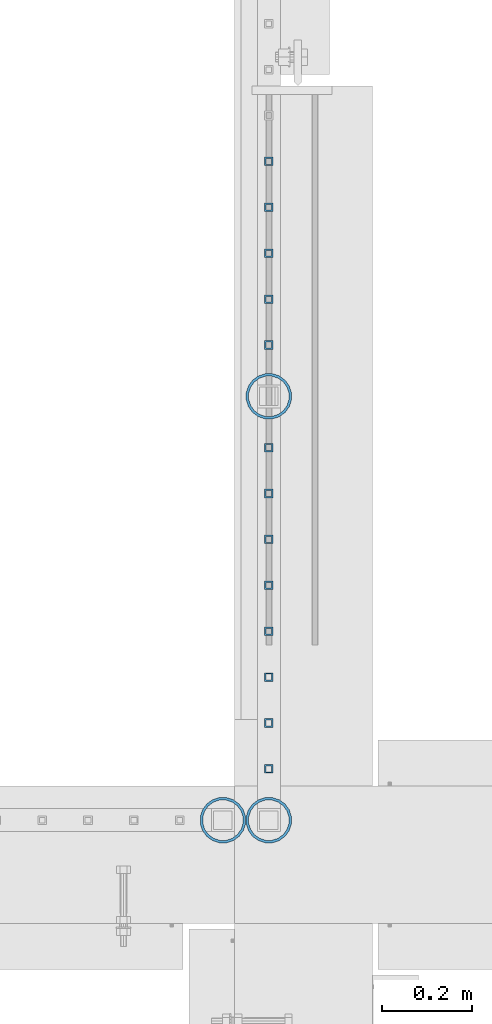
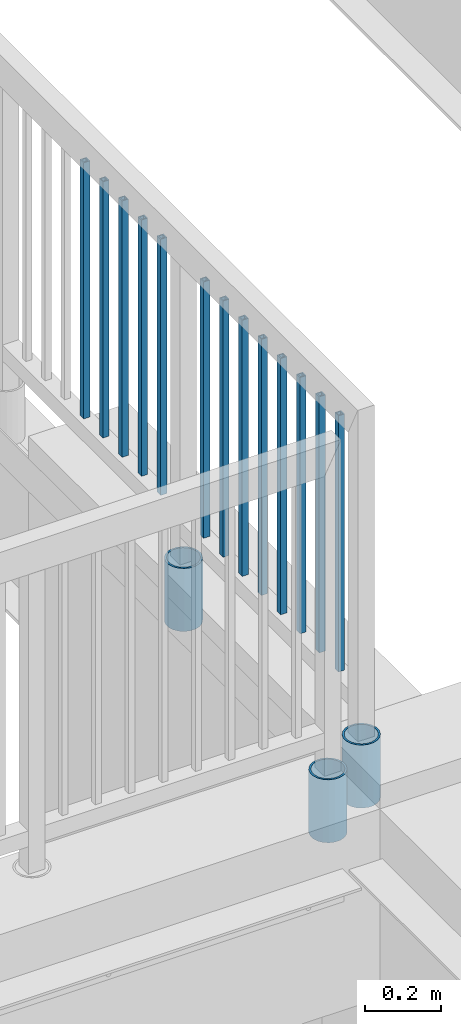
# One storey, part 212 of 975: 16 columns.
"""IFC2X3 building model written with IfcOpenShell, lengths in millimetres."""

from ifc_helpers import new_model, si_unit, frame, origin_with_axes, place, context, subcontext, project, spatial, faceted_brep, material, type_object, element, save


model = new_model("IFC2X3")

# Units and contexts
model_context = context("Model", 3, precision=1e-05, world=origin_with_axes())
body_context = subcontext(model_context, "Body", "Model", "MODEL_VIEW")
ifc_project = project(units=[si_unit("LENGTHUNIT", "METRE", prefix="MILLI"), si_unit("AREAUNIT", "SQUARE_METRE"), si_unit("VOLUMEUNIT", "CUBIC_METRE"), si_unit("MASSUNIT", "GRAM", prefix="KILO"), si_unit("TIMEUNIT", "SECOND"), si_unit("PLANEANGLEUNIT", "RADIAN"), si_unit("SOLIDANGLEUNIT", "STERADIAN"), si_unit("THERMODYNAMICTEMPERATUREUNIT", "DEGREE_CELSIUS"), si_unit("LUMINOUSINTENSITYUNIT", "LUMEN")], contexts=[model_context])

# Site, building, storey
site_placement = place(None, origin_with_axes())
site = spatial("IfcSite", under=ifc_project, at=site_placement, CompositionType="ELEMENT")
building_placement = place(site_placement, origin_with_axes())
building = spatial("IfcBuilding", under=site, at=building_placement, Name="Undefined", CompositionType="ELEMENT")
storey_placement = place(building_placement, origin_with_axes())
storey = spatial("IfcBuildingStorey", under=building, at=storey_placement, Name="Undefined", CompositionType="ELEMENT", Elevation=0.0)

# Columns
ifc_material_1 = material()
column_type_1 = type_object("IfcColumnType", Name="HSS3/4X3/4X.120_TUBES", PredefinedType="NOTDEFINED")
for number, where, z_axis, x_axis, name in (
    (1, (2091.7632059414, 22130.5416480171, 4254.50002056753), (0.0, 1.0, 0.0), (0.0, 0.0, 1.0), "PICKET"),
    (2, (2091.7632059414, 22028.9416480171, 4254.50002056753), (0.0, 1.0, 0.0), (0.0, 0.0, 1.0), "PICKET"),
    (3, (2091.7632059414, 21927.3416480171, 4254.50002056753), (0.0, 1.0, 0.0), (0.0, 0.0, 1.0), "PICKET"),
    (4, (2091.7632059414, 21825.7416480171, 4254.50002056753), (0.0, 1.0, 0.0), (0.0, 0.0, 1.0), "PICKET"),
    (5, (2091.7632059414, 21724.1416480171, 4254.50002056753), (0.0, 1.0, 0.0), (0.0, 0.0, 1.0), "PICKET"),
    (6, (2091.75174267054, 21497.1270920987, 4254.50352506861), (0.0, 1.0, 0.0), (0.0, 0.0, 1.0), "PICKET"),
    (7, (2091.75174267054, 21395.5270920987, 4254.50352506861), (0.0, 1.0, 0.0), (0.0, 0.0, 1.0), "PICKET"),
    (8, (2091.75174267054, 21293.9270920987, 4254.50352506861), (0.0, 1.0, 0.0), (0.0, 0.0, 1.0), "PICKET"),
    (9, (2091.75174267054, 21192.3270920987, 4254.50352506861), (0.0, 1.0, 0.0), (0.0, 0.0, 1.0), "PICKET"),
    (10, (2091.75174267054, 21090.7270920987, 4254.50352506861), (0.0, 1.0, 0.0), (0.0, 0.0, 1.0), "PICKET"),
    (11, (2091.75174267054, 20989.1270920987, 4254.50352506861), (0.0, 1.0, 0.0), (0.0, 0.0, 1.0), "PICKET"),
    (12, (2091.75174267054, 20887.5270920987, 4254.50352506861), (0.0, 1.0, 0.0), (0.0, 0.0, 1.0), "PICKET"),
    (13, (2091.75174267054, 20785.9270920987, 4254.50352506861), (0.0, 1.0, 0.0), (0.0, 0.0, 1.0), "PICKET"),
):
    element("IfcColumn", number, at=place(storey_placement, frame(where, z_axis=z_axis, x_axis=x_axis)), inside=storey, type_object=column_type_1, material=ifc_material_1, Name=name, ObjectType="HSS3/4X3/4X.120_TUBES", context=body_context, shape_type="Brep", body=[
        faceted_brep([(0.0, 6.34999999998763, -6.34999999998763), (0.0, -6.35000000000582, -6.34999999998763), (825.49997943247, -6.35000000000582, -6.34999999998763), (825.49997943247, 6.34999999998763, -6.34999999998763), (0.0, -6.34999999998763, 6.34999999998763), (825.49997943247, -6.34999999998763, 6.34999999998763), (0.0, 6.35000000000946, 6.34999999998763), (825.49997943247, 6.35000000000946, 6.34999999998763), (0.0, 9.52499999997963, -9.52499999997963), (0.0, 9.52500000000873, 9.5249999999869), (825.49997943247, 9.52500000000873, 9.5249999999869), (825.49997943247, 9.52499999997963, -9.52499999997963), (0.0, -9.52499999997963, 9.52499999998327), (825.49997943247, -9.52499999997963, 9.52499999998327), (0.0, -9.52500000000873, -9.5249999999869), (825.49997943247, -9.52500000000873, -9.5249999999869)], [[[0, 1, 2, 3]], [[1, 4, 5, 2]], [[4, 6, 7, 5]], [[6, 0, 3, 7]], [[8, 9, 10, 11]], [[9, 12, 13, 10]], [[12, 14, 15, 13]], [[14, 8, 11, 15]], [[13, 15, 11, 10], [5, 7, 3, 2]], [[14, 12, 9, 8], [6, 4, 1, 0]]]),
    ])
ifc_material_2 = material(Name="STEEL/A53")
column_type_2 = type_object("IfcColumnType", Name="PIPE3-1/2STD", PredefinedType="NOTDEFINED")
column_1_placement = place(storey_placement, frame((1990.12300113828, 20672.4250004, 3835.40001060704), z_axis=(-0.707106781186601, 0.707106781186494, 2.36468622460961e-14), x_axis=(0.0, 0.0, 1.0)))
element("IfcColumn", 14, at=column_1_placement, inside=storey, type_object=column_type_2, material=ifc_material_2, ObjectType="PIPE3-1/2STD", context=body_context, shape_type="Brep", body=[
    faceted_brep([(0.0, -45.0595999999932, 1.45519152283669e-11), (0.0, -42.8542262016344, 13.924182159768), (203.199999999991, -42.8542262017145, 13.9241821598171), (203.19999999999, -45.0596000000478, 5.82076609134674e-11), (0.0, -36.45398215971, 26.4853683542424), (203.199999999993, -36.45398215981, 26.4853683542988), (0.0, -26.4853683541623, 36.45398215979), (203.199999999995, -26.4853683542788, 36.4539821598537), (0.0, -13.9241821596988, 42.8542262017108), (203.199999999998, -13.9241821598262, 42.8542262017836), (0.0, 3.63797880709171e-11, 45.0596000000514), (203.2, -9.27684595808387e-11, 45.0596000001387), (0.0, 13.9241821597716, 42.8542262017036), (203.200000000003, 13.9241821596443, 42.8542262017927), (0.0, 26.4853683542242, 36.4539821597718), (203.200000000006, 26.4853683541096, 36.4539821598701), (0.0, 36.4539821597537, 26.4853683542206), (203.200000000008, 36.4539821596554, 26.4853683543224), (0.0, 42.8542262016563, 13.9241821597425), (203.200000000009, 42.8542262015817, 13.9241821598443), (0.0, 45.0595999999932, -1.09139364212751e-11), (203.200000000009, 45.0595999999423, 8.9130480773747e-11), (0.0, 42.8542262016344, -13.9241821597643), (203.200000000008, 42.854226201609, -13.9241821596697), (0.0, 36.45398215971, -26.4853683542387), (203.200000000007, 36.4539821597045, -26.4853683541514), (0.0, 26.4853683541623, -36.4539821597864), (203.200000000004, 26.4853683541733, -36.4539821597064), (0.0, 13.9241821596988, -42.8542262017072), (203.200000000002, 13.9241821597225, -42.8542262016381), (0.0, -3.63797880709171e-11, -45.0596000000478), (203.199999999999, -9.09494701772928e-12, -45.0595999999914), (0.0, -13.9241821597716, -42.8542262016963), (203.199999999996, -13.9241821597479, -42.8542262016472), (0.0, -26.4853683542242, -36.4539821597682), (203.199999999993, -26.4853683542133, -36.4539821597227), (0.0, -36.4539821597537, -26.4853683542169), (203.199999999992, -36.4539821597609, -26.4853683541751), (0.0, -42.8542262016563, -13.9241821597352), (203.199999999991, -42.8542262016872, -13.924182159697), (0.0, -50.799999999992, 1.81898940354586e-11), (0.0, -48.3136710278013, -15.6980633142484), (203.199999999989, -48.313671027825, -15.6980633142139), (203.199999999989, -50.8000000000466, 5.63886715099216e-11), (0.0, -41.0980633142644, -29.8594908164741), (203.19999999999, -41.0980633142663, -29.8594908164414), (0.0, -29.859490816485, -41.0980633142826), (203.199999999993, -29.8594908164687, -41.0980633142426), (0.0, -15.6980633142848, -48.313671027845), (203.199999999995, -15.6980633142539, -48.313671027794), (0.0, -4.36557456851006e-11, -50.8000000000575), (203.199999999998, -7.27595761418343e-12, -50.7999999999993), (0.0, 15.6980633142011, -48.3136710278523), (203.200000000002, 15.6980633142375, -48.3136710277831), (0.0, 29.8594908164159, -41.0980633143045), (203.200000000005, 29.8594908164378, -41.0980633142226), (0.0, 41.0980633142135, -29.8594908165032), (203.200000000008, 41.0980633142171, -29.8594908164141), (0.0, 48.3136710277722, -15.6980633142775), (203.200000000009, 48.3136710277504, -15.6980633141811), (0.0, 50.799999999992, -1.45519152283669e-11), (203.20000000001, 50.7999999999411, 9.09494701772928e-11), (0.0, 48.313671027794, 15.6980633142521), (203.20000000001, 48.3136710277213, 15.6980633143594), (0.0, 41.0980633142644, 29.8594908164814), (203.200000000008, 41.0980633141626, 29.8594908165887), (0.0, 29.859490816485, 41.0980633142863), (203.200000000007, 29.8594908163632, 41.0980633143899), (0.0, 15.6980633142848, 48.3136710278486), (203.200000000004, 15.6980633141484, 48.3136710279414), (0.0, 4.00177668780088e-11, 50.8000000000611), (203.200000000001, -9.82254277914762e-11, 50.8000000001466), (0.0, -15.6980633142011, 48.3136710278559), (203.199999999997, -15.698063314343, 48.3136710279305), (0.0, -29.8594908164159, 41.0980633143081), (203.199999999994, -29.8594908165433, 41.0980633143681), (0.0, -41.0980633142171, 29.8594908165069), (203.199999999992, -41.0980633143226, 29.8594908165596), (0.0, -48.3136710277722, 15.6980633142812), (203.19999999999, -48.3136710278559, 15.6980633143285)], [[[0, 1, 2, 3]], [[1, 4, 5, 2]], [[4, 6, 7, 5]], [[6, 8, 9, 7]], [[8, 10, 11, 9]], [[10, 12, 13, 11]], [[12, 14, 15, 13]], [[14, 16, 17, 15]], [[16, 18, 19, 17]], [[18, 20, 21, 19]], [[20, 22, 23, 21]], [[22, 24, 25, 23]], [[24, 26, 27, 25]], [[26, 28, 29, 27]], [[28, 30, 31, 29]], [[30, 32, 33, 31]], [[32, 34, 35, 33]], [[34, 36, 37, 35]], [[36, 38, 39, 37]], [[38, 0, 3, 39]], [[40, 41, 42, 43]], [[41, 44, 45, 42]], [[44, 46, 47, 45]], [[46, 48, 49, 47]], [[48, 50, 51, 49]], [[50, 52, 53, 51]], [[52, 54, 55, 53]], [[54, 56, 57, 55]], [[56, 58, 59, 57]], [[58, 60, 61, 59]], [[60, 62, 63, 61]], [[62, 64, 65, 63]], [[64, 66, 67, 65]], [[66, 68, 69, 67]], [[68, 70, 71, 69]], [[70, 72, 73, 71]], [[72, 74, 75, 73]], [[74, 76, 77, 75]], [[76, 78, 79, 77]], [[78, 40, 43, 79]], [[45, 47, 49, 51, 53, 55, 57, 59, 61, 63, 65, 67, 69, 71, 73, 75, 77, 79, 43, 42], [5, 7, 9, 11, 13, 15, 17, 19, 21, 23, 25, 27, 29, 31, 33, 35, 37, 39, 3, 2]], [[78, 76, 74, 72, 70, 68, 66, 64, 62, 60, 58, 56, 54, 52, 50, 48, 46, 44, 41, 40], [38, 36, 34, 32, 30, 28, 26, 24, 22, 20, 18, 16, 14, 12, 10, 8, 6, 4, 1, 0]]]),
])
column_2_placement = place(storey_placement, frame((2091.72299802514, 20672.4250004, 3911.6), z_axis=(-0.707106781186601, 0.707106781186494, 2.36468622460961e-14), x_axis=(0.0, 0.0, 1.0)))
element("IfcColumn", 15, at=column_2_placement, inside=storey, type_object=column_type_2, material=ifc_material_2, ObjectType="PIPE3-1/2STD", context=body_context, shape_type="Brep", body=[
    faceted_brep([(0.0, -45.0595999999932, 1.45519152283669e-11), (0.0, -42.8542262016344, 13.924182159768), (203.199999999991, -42.8542262017145, 13.9241821598171), (203.19999999999, -45.0596000000478, 5.82076609134674e-11), (0.0, -36.45398215971, 26.4853683542424), (203.199999999993, -36.45398215981, 26.4853683542988), (0.0, -26.4853683541623, 36.45398215979), (203.199999999995, -26.4853683542788, 36.4539821598537), (0.0, -13.9241821596988, 42.8542262017108), (203.199999999998, -13.9241821598262, 42.8542262017836), (0.0, 3.63797880709171e-11, 45.0596000000514), (203.2, -9.27684595808387e-11, 45.0596000001387), (0.0, 13.9241821597716, 42.8542262017036), (203.200000000003, 13.9241821596443, 42.8542262017927), (0.0, 26.4853683542242, 36.4539821597718), (203.200000000006, 26.4853683541096, 36.4539821598701), (0.0, 36.4539821597537, 26.4853683542206), (203.200000000008, 36.4539821596554, 26.4853683543224), (0.0, 42.8542262016563, 13.9241821597425), (203.200000000009, 42.8542262015817, 13.9241821598443), (0.0, 45.0595999999932, -1.09139364212751e-11), (203.200000000009, 45.0595999999423, 8.9130480773747e-11), (0.0, 42.8542262016344, -13.9241821597643), (203.200000000008, 42.854226201609, -13.9241821596697), (0.0, 36.45398215971, -26.4853683542387), (203.200000000007, 36.4539821597045, -26.4853683541514), (0.0, 26.4853683541623, -36.4539821597864), (203.200000000004, 26.4853683541733, -36.4539821597064), (0.0, 13.9241821596988, -42.8542262017072), (203.200000000002, 13.9241821597225, -42.8542262016381), (0.0, -3.63797880709171e-11, -45.0596000000478), (203.199999999999, -9.09494701772928e-12, -45.0595999999914), (0.0, -13.9241821597716, -42.8542262016963), (203.199999999996, -13.9241821597479, -42.8542262016472), (0.0, -26.4853683542242, -36.4539821597682), (203.199999999993, -26.4853683542133, -36.4539821597227), (0.0, -36.4539821597537, -26.4853683542169), (203.199999999992, -36.4539821597609, -26.4853683541751), (0.0, -42.8542262016563, -13.9241821597352), (203.199999999991, -42.8542262016872, -13.924182159697), (0.0, -50.799999999992, 1.81898940354586e-11), (0.0, -48.3136710278013, -15.6980633142484), (203.199999999989, -48.313671027825, -15.6980633142139), (203.199999999989, -50.8000000000466, 5.63886715099216e-11), (0.0, -41.0980633142644, -29.8594908164741), (203.19999999999, -41.0980633142663, -29.8594908164414), (0.0, -29.859490816485, -41.0980633142826), (203.199999999993, -29.8594908164687, -41.0980633142426), (0.0, -15.6980633142848, -48.313671027845), (203.199999999995, -15.6980633142539, -48.313671027794), (0.0, -4.36557456851006e-11, -50.8000000000575), (203.199999999998, -7.27595761418343e-12, -50.7999999999993), (0.0, 15.6980633142011, -48.3136710278523), (203.200000000002, 15.6980633142375, -48.3136710277831), (0.0, 29.8594908164159, -41.0980633143045), (203.200000000005, 29.8594908164378, -41.0980633142226), (0.0, 41.0980633142135, -29.8594908165032), (203.200000000008, 41.0980633142171, -29.8594908164141), (0.0, 48.3136710277722, -15.6980633142775), (203.200000000009, 48.3136710277504, -15.6980633141811), (0.0, 50.799999999992, -1.45519152283669e-11), (203.20000000001, 50.7999999999411, 9.09494701772928e-11), (0.0, 48.313671027794, 15.6980633142521), (203.20000000001, 48.3136710277213, 15.6980633143594), (0.0, 41.0980633142644, 29.8594908164814), (203.200000000008, 41.0980633141626, 29.8594908165887), (0.0, 29.859490816485, 41.0980633142863), (203.200000000007, 29.8594908163632, 41.0980633143899), (0.0, 15.6980633142848, 48.3136710278486), (203.200000000004, 15.6980633141484, 48.3136710279414), (0.0, 4.00177668780088e-11, 50.8000000000611), (203.200000000001, -9.82254277914762e-11, 50.8000000001466), (0.0, -15.6980633142011, 48.3136710278559), (203.199999999997, -15.698063314343, 48.3136710279305), (0.0, -29.8594908164159, 41.0980633143081), (203.199999999994, -29.8594908165433, 41.0980633143681), (0.0, -41.0980633142171, 29.8594908165069), (203.199999999992, -41.0980633143226, 29.8594908165596), (0.0, -48.3136710277722, 15.6980633142812), (203.19999999999, -48.3136710278559, 15.6980633143285)], [[[0, 1, 2, 3]], [[1, 4, 5, 2]], [[4, 6, 7, 5]], [[6, 8, 9, 7]], [[8, 10, 11, 9]], [[10, 12, 13, 11]], [[12, 14, 15, 13]], [[14, 16, 17, 15]], [[16, 18, 19, 17]], [[18, 20, 21, 19]], [[20, 22, 23, 21]], [[22, 24, 25, 23]], [[24, 26, 27, 25]], [[26, 28, 29, 27]], [[28, 30, 31, 29]], [[30, 32, 33, 31]], [[32, 34, 35, 33]], [[34, 36, 37, 35]], [[36, 38, 39, 37]], [[38, 0, 3, 39]], [[40, 41, 42, 43]], [[41, 44, 45, 42]], [[44, 46, 47, 45]], [[46, 48, 49, 47]], [[48, 50, 51, 49]], [[50, 52, 53, 51]], [[52, 54, 55, 53]], [[54, 56, 57, 55]], [[56, 58, 59, 57]], [[58, 60, 61, 59]], [[60, 62, 63, 61]], [[62, 64, 65, 63]], [[64, 66, 67, 65]], [[66, 68, 69, 67]], [[68, 70, 71, 69]], [[70, 72, 73, 71]], [[72, 74, 75, 73]], [[74, 76, 77, 75]], [[76, 78, 79, 77]], [[78, 40, 43, 79]], [[45, 47, 49, 51, 53, 55, 57, 59, 61, 63, 65, 67, 69, 71, 73, 75, 77, 79, 43, 42], [5, 7, 9, 11, 13, 15, 17, 19, 21, 23, 25, 27, 29, 31, 33, 35, 37, 39, 3, 2]], [[78, 76, 74, 72, 70, 68, 66, 64, 62, 60, 58, 56, 54, 52, 50, 48, 46, 44, 41, 40], [38, 36, 34, 32, 30, 28, 26, 24, 22, 20, 18, 16, 14, 12, 10, 8, 6, 4, 1, 0]]]),
])
column_3_placement = place(storey_placement, frame((2091.7784545645, 21610.6328162327, 3911.6), z_axis=(-0.707106781186601, 0.707106781186494, 2.36468622460961e-14), x_axis=(0.0, 0.0, 1.0)))
element("IfcColumn", 16, at=column_3_placement, inside=storey, type_object=column_type_2, material=ifc_material_2, ObjectType="PIPE3-1/2STD", context=body_context, shape_type="Brep", body=[
    faceted_brep([(0.0, -45.0595999999932, 1.45519152283669e-11), (0.0, -42.8542262016344, 13.924182159768), (203.199999999991, -42.8542262017145, 13.9241821598171), (203.19999999999, -45.0596000000478, 5.82076609134674e-11), (0.0, -36.45398215971, 26.4853683542424), (203.199999999993, -36.45398215981, 26.4853683542988), (0.0, -26.4853683541623, 36.45398215979), (203.199999999995, -26.4853683542788, 36.4539821598537), (0.0, -13.9241821596988, 42.8542262017108), (203.199999999998, -13.9241821598262, 42.8542262017836), (0.0, 3.63797880709171e-11, 45.0596000000514), (203.2, -9.27684595808387e-11, 45.0596000001387), (0.0, 13.9241821597716, 42.8542262017036), (203.200000000003, 13.9241821596443, 42.8542262017927), (0.0, 26.4853683542242, 36.4539821597718), (203.200000000006, 26.4853683541096, 36.4539821598701), (0.0, 36.4539821597537, 26.4853683542206), (203.200000000008, 36.4539821596554, 26.4853683543224), (0.0, 42.8542262016563, 13.9241821597425), (203.200000000009, 42.8542262015817, 13.9241821598443), (0.0, 45.0595999999932, -1.09139364212751e-11), (203.200000000009, 45.0595999999423, 8.9130480773747e-11), (0.0, 42.8542262016344, -13.9241821597643), (203.200000000008, 42.854226201609, -13.9241821596697), (0.0, 36.45398215971, -26.4853683542387), (203.200000000007, 36.4539821597045, -26.4853683541514), (0.0, 26.4853683541623, -36.4539821597864), (203.200000000004, 26.4853683541733, -36.4539821597064), (0.0, 13.9241821596988, -42.8542262017072), (203.200000000002, 13.9241821597225, -42.8542262016381), (0.0, -3.63797880709171e-11, -45.0596000000478), (203.199999999999, -9.09494701772928e-12, -45.0595999999914), (0.0, -13.9241821597716, -42.8542262016963), (203.199999999996, -13.9241821597479, -42.8542262016472), (0.0, -26.4853683542242, -36.4539821597682), (203.199999999993, -26.4853683542133, -36.4539821597227), (0.0, -36.4539821597537, -26.4853683542169), (203.199999999992, -36.4539821597609, -26.4853683541751), (0.0, -42.8542262016563, -13.9241821597352), (203.199999999991, -42.8542262016872, -13.924182159697), (0.0, -50.799999999992, 1.81898940354586e-11), (0.0, -48.3136710278013, -15.6980633142484), (203.199999999989, -48.313671027825, -15.6980633142139), (203.199999999989, -50.8000000000466, 5.63886715099216e-11), (0.0, -41.0980633142644, -29.8594908164741), (203.19999999999, -41.0980633142663, -29.8594908164414), (0.0, -29.859490816485, -41.0980633142826), (203.199999999993, -29.8594908164687, -41.0980633142426), (0.0, -15.6980633142848, -48.313671027845), (203.199999999995, -15.6980633142539, -48.313671027794), (0.0, -4.36557456851006e-11, -50.8000000000575), (203.199999999998, -7.27595761418343e-12, -50.7999999999993), (0.0, 15.6980633142011, -48.3136710278523), (203.200000000002, 15.6980633142375, -48.3136710277831), (0.0, 29.8594908164159, -41.0980633143045), (203.200000000005, 29.8594908164378, -41.0980633142226), (0.0, 41.0980633142135, -29.8594908165032), (203.200000000008, 41.0980633142171, -29.8594908164141), (0.0, 48.3136710277722, -15.6980633142775), (203.200000000009, 48.3136710277504, -15.6980633141811), (0.0, 50.799999999992, -1.45519152283669e-11), (203.20000000001, 50.7999999999411, 9.09494701772928e-11), (0.0, 48.313671027794, 15.6980633142521), (203.20000000001, 48.3136710277213, 15.6980633143594), (0.0, 41.0980633142644, 29.8594908164814), (203.200000000008, 41.0980633141626, 29.8594908165887), (0.0, 29.859490816485, 41.0980633142863), (203.200000000007, 29.8594908163632, 41.0980633143899), (0.0, 15.6980633142848, 48.3136710278486), (203.200000000004, 15.6980633141484, 48.3136710279414), (0.0, 4.00177668780088e-11, 50.8000000000611), (203.200000000001, -9.82254277914762e-11, 50.8000000001466), (0.0, -15.6980633142011, 48.3136710278559), (203.199999999997, -15.698063314343, 48.3136710279305), (0.0, -29.8594908164159, 41.0980633143081), (203.199999999994, -29.8594908165433, 41.0980633143681), (0.0, -41.0980633142171, 29.8594908165069), (203.199999999992, -41.0980633143226, 29.8594908165596), (0.0, -48.3136710277722, 15.6980633142812), (203.19999999999, -48.3136710278559, 15.6980633143285)], [[[0, 1, 2, 3]], [[1, 4, 5, 2]], [[4, 6, 7, 5]], [[6, 8, 9, 7]], [[8, 10, 11, 9]], [[10, 12, 13, 11]], [[12, 14, 15, 13]], [[14, 16, 17, 15]], [[16, 18, 19, 17]], [[18, 20, 21, 19]], [[20, 22, 23, 21]], [[22, 24, 25, 23]], [[24, 26, 27, 25]], [[26, 28, 29, 27]], [[28, 30, 31, 29]], [[30, 32, 33, 31]], [[32, 34, 35, 33]], [[34, 36, 37, 35]], [[36, 38, 39, 37]], [[38, 0, 3, 39]], [[40, 41, 42, 43]], [[41, 44, 45, 42]], [[44, 46, 47, 45]], [[46, 48, 49, 47]], [[48, 50, 51, 49]], [[50, 52, 53, 51]], [[52, 54, 55, 53]], [[54, 56, 57, 55]], [[56, 58, 59, 57]], [[58, 60, 61, 59]], [[60, 62, 63, 61]], [[62, 64, 65, 63]], [[64, 66, 67, 65]], [[66, 68, 69, 67]], [[68, 70, 71, 69]], [[70, 72, 73, 71]], [[72, 74, 75, 73]], [[74, 76, 77, 75]], [[76, 78, 79, 77]], [[78, 40, 43, 79]], [[45, 47, 49, 51, 53, 55, 57, 59, 61, 63, 65, 67, 69, 71, 73, 75, 77, 79, 43, 42], [5, 7, 9, 11, 13, 15, 17, 19, 21, 23, 25, 27, 29, 31, 33, 35, 37, 39, 3, 2]], [[78, 76, 74, 72, 70, 68, 66, 64, 62, 60, 58, 56, 54, 52, 50, 48, 46, 44, 41, 40], [38, 36, 34, 32, 30, 28, 26, 24, 22, 20, 18, 16, 14, 12, 10, 8, 6, 4, 1, 0]]]),
])

save(model, "model.ifc")
